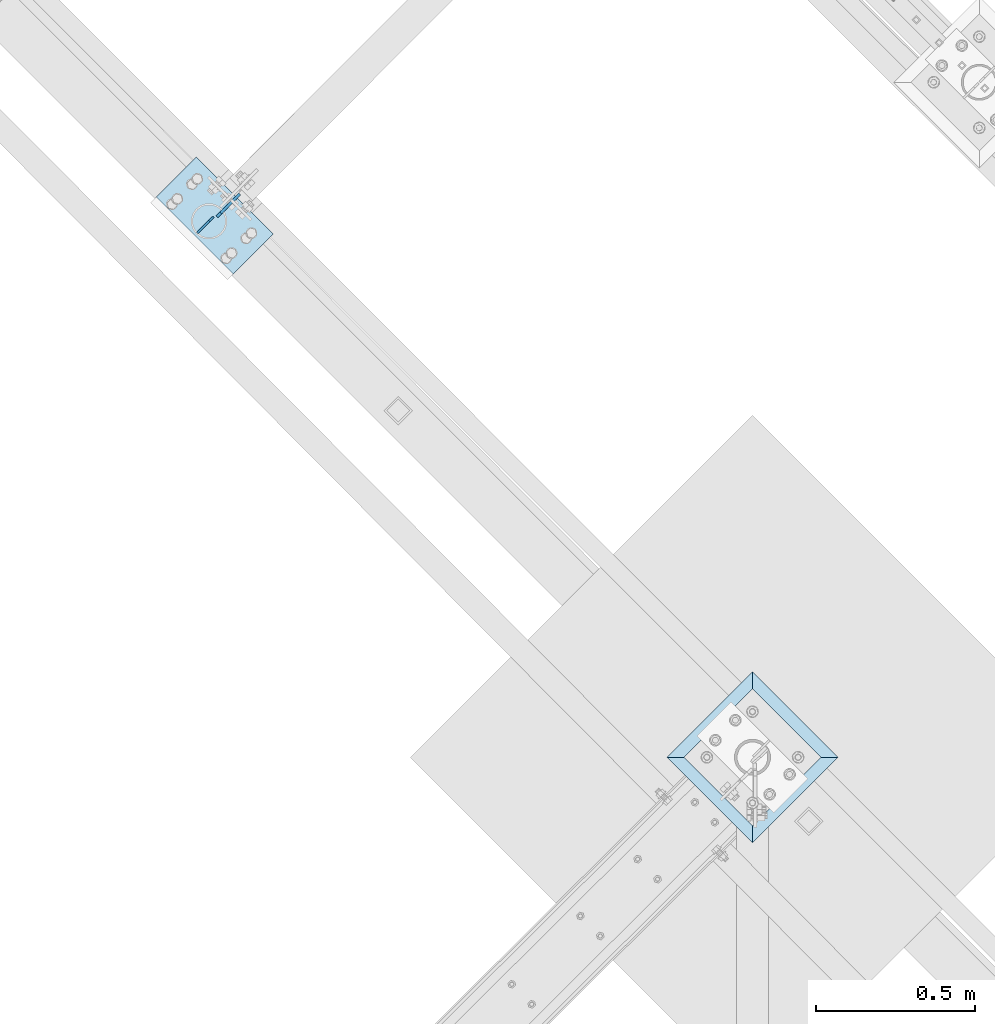
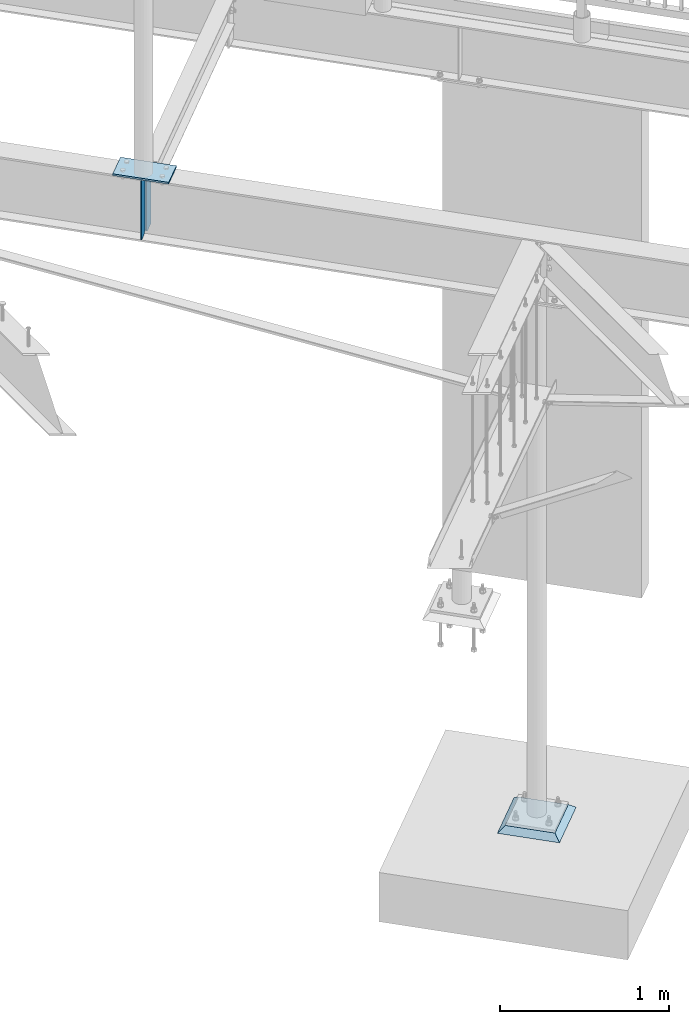
# One storey, part 925 of 975: 4 plates.
"""IFC2X3 building model written with IfcOpenShell, lengths in millimetres."""

from ifc_helpers import new_model, si_unit, frame, origin_with_axes, place, context, subcontext, project, spatial, faceted_brep, material, type_object, element, save


model = new_model("IFC2X3")

# Units and contexts
model_context = context("Model", 3, precision=1e-05, world=origin_with_axes())
body_context = subcontext(model_context, "Body", "Model", "MODEL_VIEW")
ifc_project = project(units=[si_unit("LENGTHUNIT", "METRE", prefix="MILLI"), si_unit("AREAUNIT", "SQUARE_METRE"), si_unit("VOLUMEUNIT", "CUBIC_METRE"), si_unit("MASSUNIT", "GRAM", prefix="KILO"), si_unit("TIMEUNIT", "SECOND"), si_unit("PLANEANGLEUNIT", "RADIAN"), si_unit("SOLIDANGLEUNIT", "STERADIAN"), si_unit("THERMODYNAMICTEMPERATUREUNIT", "DEGREE_CELSIUS"), si_unit("LUMINOUSINTENSITYUNIT", "LUMEN")], contexts=[model_context])

# Site, building, storey
site_placement = place(None, origin_with_axes())
site = spatial("IfcSite", under=ifc_project, at=site_placement, CompositionType="ELEMENT")
building_placement = place(site_placement, origin_with_axes())
building = spatial("IfcBuilding", under=site, at=building_placement, Name="Undefined", CompositionType="ELEMENT")
storey_placement = place(building_placement, origin_with_axes())
storey = spatial("IfcBuildingStorey", under=building, at=storey_placement, Name="Undefined", CompositionType="ELEMENT", Elevation=0.0)

# Plates
ifc_material_1 = material(Name="STEEL/A36")
plate_type_1 = type_object("IfcPlateType", PredefinedType="NOTDEFINED")
plate_1_placement = place(storey_placement, frame((28145.8714364227, 17666.012626691, 3495.67500000002), z_axis=(0.0, 0.0, 1.0), x_axis=(0.706311124041062, 0.707901544041155, 0.0)))
element("IfcPlate", 1, at=plate_1_placement, inside=storey, type_object=plate_type_1, material=ifc_material_1, Name="PLATE", context=body_context, shape_type="Brep", body=[
    faceted_brep([(0.0, -4.76250000000073, 17.4624996185303), (0.0, -4.76250000000073, 411.16250038147), (0.0, 4.76250000000073, 411.16250038147), (0.0, 4.76250000000073, 17.4624996185303), (17.4624996185303, -4.76250000000073, 428.625), (17.4624996185303, 4.76250000000073, 428.625), (101.600006103516, -4.76250000000073, 428.625), (101.600006103516, 4.76250000000073, 428.625), (101.600006103516, -4.76250000000073, 0.0), (101.600006103516, 4.76250000000073, 0.0), (17.4624996185303, -4.76250000000073, 0.0), (17.4624996185303, 4.76250000000073, 0.0)], [[[0, 1, 2, 3]], [[1, 4, 5, 2]], [[4, 6, 7, 5]], [[6, 8, 9, 7]], [[8, 10, 11, 9]], [[10, 0, 3, 11]], [[5, 7, 9, 11, 3, 2]], [[10, 8, 6, 4, 1, 0]]]),
])
plate_type_2 = type_object("IfcPlateType", PredefinedType="NOTDEFINED")
plate_2_placement = place(storey_placement, frame((28083.8447770549, 17614.6671734621, 3924.30000000001), z_axis=(0.0, 0.0, -1.0), x_axis=(0.709199573009271, 0.70500777700921, 0.0)))
element("IfcPlate", 2, at=plate_2_placement, inside=storey, type_object=plate_type_2, material=ifc_material_1, Name="PLATE", context=body_context, shape_type="Brep", body=[
    faceted_brep([(0.0, -3.17499999999927, 0.0), (0.0, -3.17499999999927, 428.625), (0.0, 3.17499999999927, 428.625), (0.0, 3.17499999999927, 0.0), (53.1812477111816, -3.17499999999927, 428.625), (53.1812477111816, 3.17499999999927, 428.625), (72.2312469482422, -3.17499999999927, 409.575000762939), (72.2312469482422, 3.17499999999927, 409.575000762939), (72.2312469482422, -3.17499999999927, 19.0499992370605), (72.2312469482422, 3.17499999999927, 19.0499992370605), (53.1812477111816, -3.17499999999927, 0.0), (53.1812477111816, 3.17499999999927, 0.0)], [[[0, 1, 2, 3]], [[1, 4, 5, 2]], [[4, 6, 7, 5]], [[6, 8, 9, 7]], [[8, 10, 11, 9]], [[10, 0, 3, 11]], [[5, 7, 9, 11, 3, 2]], [[10, 8, 6, 4, 1, 0]]]),
])
plate_type_3 = type_object("IfcPlateType", PredefinedType="NOTDEFINED")
plate_3_placement = place(storey_placement, frame((28080.7600001583, 17853.8286905218, 3943.34999999999), z_axis=(0.707106781186513, -0.707106781186582, 3.1377567211166e-14), x_axis=(-0.707106781186548, -0.707106781186548, 0.0)))
element("IfcPlate", 3, at=plate_3_placement, inside=storey, type_object=plate_type_3, material=ifc_material_1, Name="PLATE", context=body_context, shape_type="Brep", body=[
    faceted_brep([(0.0, -6.34999999998763, -3.63797880709171e-12), (-4.32919478043914e-10, -6.34999999999991, 342.899993895661), (-4.32919478043914e-10, 6.34999999999991, 342.899993895661), (0.0, 6.34999999999491, 5.45696821063757e-12), (177.800003051329, -6.34999999999991, 342.899993895658), (177.800003051329, 6.34999999999991, 342.899993895658), (177.800003051329, -6.34999999999991, -2.22826201934367e-10), (177.800003051329, 6.34999999999991, -2.22826201934367e-10)], [[[0, 1, 2, 3]], [[1, 4, 5, 2]], [[4, 6, 7, 5]], [[6, 0, 3, 7]], [[5, 7, 3, 2]], [[6, 4, 1, 0]]]),
])
ifc_material_2 = material(Name="CONCRETE/GROUT")
plate_type_4 = type_object("IfcPlateType", PredefinedType="NOTDEFINED")
plate_4_placement = place(storey_placement, frame((30101.7076836314, 15963.9, -285.75), z_axis=(-0.707106781186548, -0.707106781186548, 0.0), x_axis=(-0.707106781186601, 0.707106781186494, 2.36468622460961e-14)))
element("IfcPlate", 4, at=plate_4_placement, inside=storey, type_object=plate_type_4, material=ifc_material_2, Name="GROUT", context=body_context, shape_type="Brep", body=[
    faceted_brep([(38.1000000096292, -19.05, 342.899999985777), (0.0, 19.05, 381.0), (2.63382389675826e-07, 19.0500000000138, 0.0), (38.1000000092372, -19.05, 38.1000000116328), (342.899999988684, -19.05, 38.1000000120257), (381.0, 19.05, 0.0), (381.0, 19.05, 381.0), (342.899999989076, -19.05, 342.89999998617)], [[[0, 1, 2, 3]], [[4, 5, 6, 7]], [[4, 7, 0, 3]], [[5, 4, 3, 2]], [[6, 5, 2, 1]], [[7, 6, 1, 0]]]),
])

save(model, "model.ifc")
